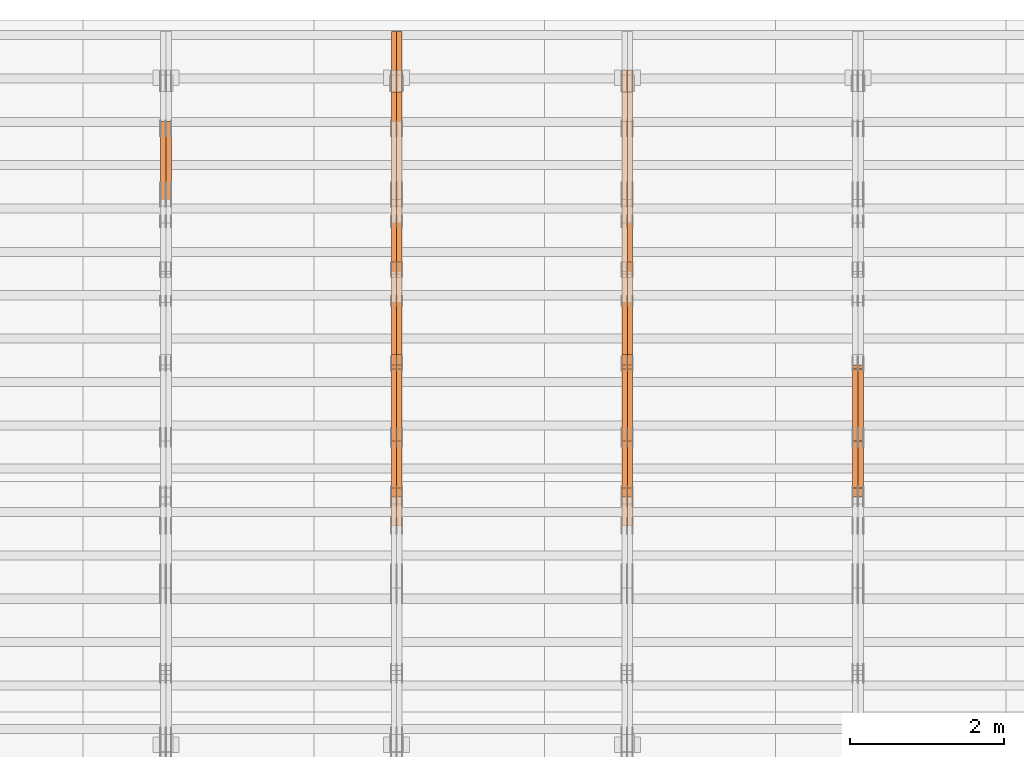
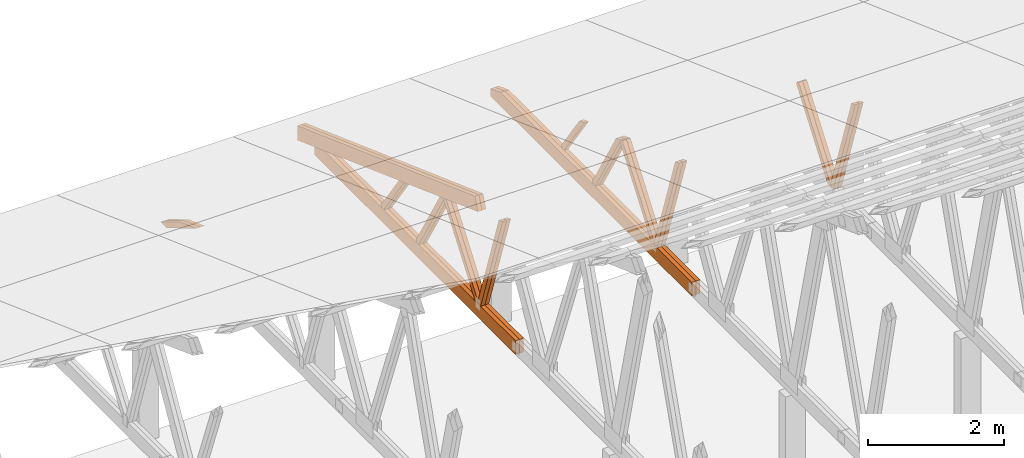
# One storey, part 44 of 189: 27 proxies.
"""IFC2X3 building model written with IfcOpenShell, lengths in millimetres."""

from ifc_helpers import new_model, entity, si_unit, converted_unit, derived_unit, direction, frame, origin, place, context, subcontext, project, spatial, polyline, outline, extrude, source, transform, mapped, material, type_object, type_shapes, element, save


model = new_model("IFC2X3")

# Units and contexts
model_context = context("Model", 3, precision=0.01, world=origin(), true_north=direction((6.12303176911189e-17, 1.0)))
body_context = subcontext(model_context, "Body", "Model", "MODEL_VIEW")
ifc_project = project(units=[si_unit("LENGTHUNIT", "METRE", prefix="MILLI"), si_unit("AREAUNIT", "SQUARE_METRE"), si_unit("VOLUMEUNIT", "CUBIC_METRE"), converted_unit("PLANEANGLEUNIT", "DEGREE", entity("IfcRatioMeasure", 0.0174532925199433), si_unit("PLANEANGLEUNIT", "RADIAN"), dimensions=[0, 0, 0, 0, 0, 0, 0]), si_unit("MASSUNIT", "GRAM", prefix="KILO"), derived_unit("MASSDENSITYUNIT", [(si_unit("MASSUNIT", "GRAM", prefix="KILO"), 1), (si_unit("LENGTHUNIT", "METRE"), -3)]), si_unit("TIMEUNIT", "SECOND"), si_unit("FREQUENCYUNIT", "HERTZ"), si_unit("THERMODYNAMICTEMPERATUREUNIT", "DEGREE_CELSIUS"), derived_unit("THERMALTRANSMITTANCEUNIT", [(si_unit("MASSUNIT", "GRAM", prefix="KILO"), 1), (si_unit("THERMODYNAMICTEMPERATUREUNIT", "KELVIN"), -1), (si_unit("TIMEUNIT", "SECOND"), -3)]), derived_unit("VOLUMETRICFLOWRATEUNIT", [(si_unit("LENGTHUNIT", "METRE"), 3), (si_unit("TIMEUNIT", "SECOND"), -1)]), si_unit("ELECTRICCURRENTUNIT", "AMPERE"), si_unit("ELECTRICVOLTAGEUNIT", "VOLT"), si_unit("POWERUNIT", "WATT"), si_unit("FORCEUNIT", "NEWTON"), si_unit("ILLUMINANCEUNIT", "LUX"), si_unit("LUMINOUSFLUXUNIT", "LUMEN"), si_unit("LUMINOUSINTENSITYUNIT", "CANDELA"), derived_unit("USERDEFINED", [(si_unit("MASSUNIT", "GRAM", prefix="KILO"), -1), (si_unit("LENGTHUNIT", "METRE"), -2), (si_unit("TIMEUNIT", "SECOND"), 3), (si_unit("LUMINOUSFLUXUNIT", "LUMEN"), 1)]), derived_unit("LINEARVELOCITYUNIT", [(si_unit("LENGTHUNIT", "METRE"), 1), (si_unit("TIMEUNIT", "SECOND"), -1)]), si_unit("PRESSUREUNIT", "PASCAL"), derived_unit("USERDEFINED", [(si_unit("LENGTHUNIT", "METRE"), -2), (si_unit("MASSUNIT", "GRAM", prefix="KILO"), 1), (si_unit("TIMEUNIT", "SECOND"), -2)])], contexts=[model_context])

# Site, building, storey
site_placement = place(None, origin())
site = spatial("IfcSite", under=ifc_project, at=site_placement, CompositionType="ELEMENT")
building_placement = place(site_placement, origin())
building = spatial("IfcBuilding", under=site, at=building_placement, CompositionType="ELEMENT")
storey_placement = place(building_placement, origin())
storey = spatial("IfcBuildingStorey", under=building, at=storey_placement, Name="Default", CompositionType="ELEMENT", Elevation=0.0)

# Proxies
ifc_material_1 = material(Name="IfcSurfaceStyle #161130")
building_element_proxy_type_1 = type_object("IfcBuildingElementProxyType", Name="T1-W9 161128", PredefinedType="NOTDEFINED", material=ifc_material_1)
shared_shape_1 = source(origin(), body_context, "Body", "SweptSolid", [
    extrude(outline(polyline([(-1151.44310138162, -47.5000079487596), (776.329826327547, -47.5000079487596), (809.267611644053, -8.1966354137375e-07), (793.242530238244, 47.5000083585914), (-1227.39686682822, 47.5000083585914), (-1151.44310138162, -47.5000079487596)])), frame((809.267685789073, 47.5000083585914, 0.0), z_axis=(0.0, 0.0, 1.0), x_axis=(-1.0, 0.0, 0.0)), (0.0, 0.0, 1.0), 69.9999999999999),
])
type_shapes(building_element_proxy_type_1, [shared_shape_1])
proxy_1_placement = place(building_placement, frame((30300.0, 24600.2198992919, 229.815691184017), z_axis=(-1.0, 0.0, 0.0), x_axis=(0.0, -0.31966811847134, 0.947529574226047)))
element("IfcBuildingElementProxy", 1, at=proxy_1_placement, inside=storey, type_object=building_element_proxy_type_1, material=ifc_material_1, Name="T1-W9", context=body_context, shape_type="MappedRepresentation", body=[
    mapped(shared_shape_1, transform((0.0, 0.0, 0.0), scale=1.0)),
])
ifc_material_2 = material(Name="IfcSurfaceStyle #161064")
building_element_proxy_type_2 = type_object("IfcBuildingElementProxyType", Name="T1-W9 161062", PredefinedType="NOTDEFINED", material=ifc_material_2)
shared_shape_2 = source(origin(), body_context, "Body", "SweptSolid", [
    extrude(outline(polyline([(-1151.44310138162, -47.5000079487596), (776.329826327547, -47.5000079487596), (809.267611644053, -8.1966354137375e-07), (793.242530238244, 47.5000083585914), (-1227.39686682822, 47.5000083585914), (-1151.44310138162, -47.5000079487596)])), frame((809.267685789073, 47.5000083585914, 0.0), z_axis=(0.0, 0.0, 1.0), x_axis=(-1.0, 0.0, 0.0)), (0.0, 0.0, 1.0), 69.9999999999999),
])
type_shapes(building_element_proxy_type_2, [shared_shape_2])
proxy_2_placement = place(building_placement, frame((30230.0, 24600.2198992919, 229.815691184017), z_axis=(-1.0, 0.0, 0.0), x_axis=(0.0, -0.31966811847134, 0.947529574226047)))
element("IfcBuildingElementProxy", 2, at=proxy_2_placement, inside=storey, type_object=building_element_proxy_type_2, material=ifc_material_2, Name="T1-W9", context=body_context, shape_type="MappedRepresentation", body=[
    mapped(shared_shape_2, transform((0.0, 0.0, 0.0), scale=1.0)),
])
ifc_material_3 = material(Name="IfcSurfaceStyle #160866")
building_element_proxy_type_3 = type_object("IfcBuildingElementProxyType", Name="T1-W10 160864", PredefinedType="NOTDEFINED", material=ifc_material_3)
shared_shape_3 = source(origin(), body_context, "Body", "SweptSolid", [
    extrude(outline(polyline([(-993.240970354386, -47.5000757607337), (635.890952815036, -47.5000757607337), (650.068145237537, -1.47580554758164e-05), (629.921374092803, 47.5000831397614), (-922.639501790989, 47.5000831397614), (-993.240970354386, -47.5000757607337)])), frame((650.068173419645, 47.5002811208496, 0.0), z_axis=(0.0, 0.0, 1.0), x_axis=(-1.0, 0.0, 0.0)), (0.0, 0.0, 1.0), 69.9999999999999),
])
type_shapes(building_element_proxy_type_3, [shared_shape_3])
proxy_3_placement = place(building_placement, frame((30300.0, 25701.688098798, 1507.2920009025), z_axis=(-1.0, 0.0, 0.0), x_axis=(0.0, -0.596486092002004, -0.802623412347395)))
element("IfcBuildingElementProxy", 3, at=proxy_3_placement, inside=storey, type_object=building_element_proxy_type_3, material=ifc_material_3, Name="T1-W10", context=body_context, shape_type="MappedRepresentation", body=[
    mapped(shared_shape_3, transform((0.0, 0.0, 0.0), scale=1.0)),
])
ifc_material_4 = material(Name="IfcSurfaceStyle #160800")
building_element_proxy_type_4 = type_object("IfcBuildingElementProxyType", Name="T1-W10 160798", PredefinedType="NOTDEFINED", material=ifc_material_4)
shared_shape_4 = source(origin(), body_context, "Body", "SweptSolid", [
    extrude(outline(polyline([(-993.240970354386, -47.5000757607337), (635.890952815036, -47.5000757607337), (650.068145237537, -1.47580554758164e-05), (629.921374092803, 47.5000831397614), (-922.639501790989, 47.5000831397614), (-993.240970354386, -47.5000757607337)])), frame((650.068173419645, 47.5002811208496, 0.0), z_axis=(0.0, 0.0, 1.0), x_axis=(-1.0, 0.0, 0.0)), (0.0, 0.0, 1.0), 69.9999999999999),
])
type_shapes(building_element_proxy_type_4, [shared_shape_4])
proxy_4_placement = place(building_placement, frame((30230.0, 25701.688098798, 1507.2920009025), z_axis=(-1.0, 0.0, 0.0), x_axis=(0.0, -0.596486092002004, -0.802623412347395)))
element("IfcBuildingElementProxy", 4, at=proxy_4_placement, inside=storey, type_object=building_element_proxy_type_4, material=ifc_material_4, Name="T1-W10", context=body_context, shape_type="MappedRepresentation", body=[
    mapped(shared_shape_4, transform((0.0, 0.0, 0.0), scale=1.0)),
])
ifc_material_5 = material(Name="IfcSurfaceStyle #145340")
building_element_proxy_type_5 = type_object("IfcBuildingElementProxyType", Name="T1-W9 145338", PredefinedType="NOTDEFINED", material=ifc_material_5)
shared_shape_5 = source(origin(), body_context, "Body", "SweptSolid", [
    extrude(outline(polyline([(-1151.44310138162, -47.5000079487596), (776.329826327547, -47.5000079487596), (809.267611644053, -8.1966354137375e-07), (793.242530238244, 47.5000083585914), (-1227.39686682822, 47.5000083585914), (-1151.44310138162, -47.5000079487596)])), frame((809.267685789073, 47.5000083585914, 0.0), z_axis=(0.0, 0.0, 1.0), x_axis=(-1.0, 0.0, 0.0)), (0.0, 0.0, 1.0), 69.9999999999999),
])
type_shapes(building_element_proxy_type_5, [shared_shape_5])
proxy_5_placement = place(building_placement, frame((27300.0, 24600.2198992919, 229.815691184017), z_axis=(-1.0, 0.0, 0.0), x_axis=(0.0, -0.31966811847134, 0.947529574226047)))
element("IfcBuildingElementProxy", 5, at=proxy_5_placement, inside=storey, type_object=building_element_proxy_type_5, material=ifc_material_5, Name="T1-W9", context=body_context, shape_type="MappedRepresentation", body=[
    mapped(shared_shape_5, transform((0.0, 0.0, 0.0), scale=1.0)),
])
ifc_material_6 = material(Name="IfcSurfaceStyle #145274")
building_element_proxy_type_6 = type_object("IfcBuildingElementProxyType", Name="T1-W9 145272", PredefinedType="NOTDEFINED", material=ifc_material_6)
shared_shape_6 = source(origin(), body_context, "Body", "SweptSolid", [
    extrude(outline(polyline([(-1151.44310138162, -47.5000079487596), (776.329826327547, -47.5000079487596), (809.267611644053, -8.1966354137375e-07), (793.242530238244, 47.5000083585914), (-1227.39686682822, 47.5000083585914), (-1151.44310138162, -47.5000079487596)])), frame((809.267685789073, 47.5000083585914, 0.0), z_axis=(0.0, 0.0, 1.0), x_axis=(-1.0, 0.0, 0.0)), (0.0, 0.0, 1.0), 69.9999999999999),
])
type_shapes(building_element_proxy_type_6, [shared_shape_6])
proxy_6_placement = place(building_placement, frame((27230.0, 24600.2198992919, 229.815691184017), z_axis=(-1.0, 0.0, 0.0), x_axis=(0.0, -0.31966811847134, 0.947529574226047)))
element("IfcBuildingElementProxy", 6, at=proxy_6_placement, inside=storey, type_object=building_element_proxy_type_6, material=ifc_material_6, Name="T1-W9", context=body_context, shape_type="MappedRepresentation", body=[
    mapped(shared_shape_6, transform((0.0, 0.0, 0.0), scale=1.0)),
])
ifc_material_7 = material(Name="IfcSurfaceStyle #145076")
building_element_proxy_type_7 = type_object("IfcBuildingElementProxyType", Name="T1-W10 145074", PredefinedType="NOTDEFINED", material=ifc_material_7)
shared_shape_7 = source(origin(), body_context, "Body", "SweptSolid", [
    extrude(outline(polyline([(-993.240970354386, -47.5000757607337), (635.890952815036, -47.5000757607337), (650.068145237537, -1.47580554758164e-05), (629.921374092803, 47.5000831397614), (-922.639501790989, 47.5000831397614), (-993.240970354386, -47.5000757607337)])), frame((650.068173419645, 47.5002811208496, 0.0), z_axis=(0.0, 0.0, 1.0), x_axis=(-1.0, 0.0, 0.0)), (0.0, 0.0, 1.0), 69.9999999999999),
])
type_shapes(building_element_proxy_type_7, [shared_shape_7])
proxy_7_placement = place(building_placement, frame((27300.0, 25701.688098798, 1507.2920009025), z_axis=(-1.0, 0.0, 0.0), x_axis=(0.0, -0.596486092002004, -0.802623412347395)))
element("IfcBuildingElementProxy", 7, at=proxy_7_placement, inside=storey, type_object=building_element_proxy_type_7, material=ifc_material_7, Name="T1-W10", context=body_context, shape_type="MappedRepresentation", body=[
    mapped(shared_shape_7, transform((0.0, 0.0, 0.0), scale=1.0)),
])
ifc_material_8 = material(Name="IfcSurfaceStyle #145010")
building_element_proxy_type_8 = type_object("IfcBuildingElementProxyType", Name="T1-W10 145008", PredefinedType="NOTDEFINED", material=ifc_material_8)
shared_shape_8 = source(origin(), body_context, "Body", "SweptSolid", [
    extrude(outline(polyline([(-993.240970354386, -47.5000757607337), (635.890952815036, -47.5000757607337), (650.068145237537, -1.47580554758164e-05), (629.921374092803, 47.5000831397614), (-922.639501790989, 47.5000831397614), (-993.240970354386, -47.5000757607337)])), frame((650.068173419645, 47.5002811208496, 0.0), z_axis=(0.0, 0.0, 1.0), x_axis=(-1.0, 0.0, 0.0)), (0.0, 0.0, 1.0), 69.9999999999999),
])
type_shapes(building_element_proxy_type_8, [shared_shape_8])
proxy_8_placement = place(building_placement, frame((27230.0, 25701.688098798, 1507.2920009025), z_axis=(-1.0, 0.0, 0.0), x_axis=(0.0, -0.596486092002004, -0.802623412347395)))
element("IfcBuildingElementProxy", 8, at=proxy_8_placement, inside=storey, type_object=building_element_proxy_type_8, material=ifc_material_8, Name="T1-W10", context=body_context, shape_type="MappedRepresentation", body=[
    mapped(shared_shape_8, transform((0.0, 0.0, 0.0), scale=1.0)),
])
ifc_material_9 = material(Name="IfcSurfaceStyle #144812")
building_element_proxy_type_9 = type_object("IfcBuildingElementProxyType", Name="T1-W11 144810", PredefinedType="NOTDEFINED", material=ifc_material_9)
shared_shape_9 = source(origin(), body_context, "Body", "SweptSolid", [
    extrude(outline(polyline([(-809.410890003667, -47.5000077306544), (561.624013869753, -47.5000077306544), (599.944137054867, -7.52294285037536e-05), (572.078784657538, 47.5000453453687), (-924.236045578491, 47.5000453453687), (-809.410890003667, -47.5000077306544)])), frame((599.944137054867, 47.5000453453687, 0.0), z_axis=(0.0, 0.0, 1.0), x_axis=(-1.0, 0.0, 0.0)), (0.0, 0.0, 1.0), 69.9999999999999),
])
type_shapes(building_element_proxy_type_9, [shared_shape_9])
proxy_9_placement = place(building_placement, frame((27300.0, 26434.7921369083, 220.965133687368), z_axis=(-1.0, 0.0, 0.0), x_axis=(0.0, -0.505995901100603, 0.862535882192381)))
element("IfcBuildingElementProxy", 9, at=proxy_9_placement, inside=storey, type_object=building_element_proxy_type_9, material=ifc_material_9, Name="T1-W11", context=body_context, shape_type="MappedRepresentation", body=[
    mapped(shared_shape_9, transform((0.0, 0.0, 0.0), scale=1.0)),
])
ifc_material_10 = material(Name="IfcSurfaceStyle #144746")
building_element_proxy_type_10 = type_object("IfcBuildingElementProxyType", Name="T1-W11 144744", PredefinedType="NOTDEFINED", material=ifc_material_10)
shared_shape_10 = source(origin(), body_context, "Body", "SweptSolid", [
    extrude(outline(polyline([(-809.410890003667, -47.5000077306544), (561.624013869753, -47.5000077306544), (599.944137054867, -7.52294285037536e-05), (572.078784657538, 47.5000453453687), (-924.236045578491, 47.5000453453687), (-809.410890003667, -47.5000077306544)])), frame((599.944137054867, 47.5000453453687, 0.0), z_axis=(0.0, 0.0, 1.0), x_axis=(-1.0, 0.0, 0.0)), (0.0, 0.0, 1.0), 69.9999999999999),
])
type_shapes(building_element_proxy_type_10, [shared_shape_10])
proxy_10_placement = place(building_placement, frame((27230.0, 26434.7921369083, 220.965133687368), z_axis=(-1.0, 0.0, 0.0), x_axis=(0.0, -0.505995901100603, 0.862535882192381)))
element("IfcBuildingElementProxy", 10, at=proxy_10_placement, inside=storey, type_object=building_element_proxy_type_10, material=ifc_material_10, Name="T1-W11", context=body_context, shape_type="MappedRepresentation", body=[
    mapped(shared_shape_10, transform((0.0, 0.0, 0.0), scale=1.0)),
])
ifc_material_11 = material(Name="IfcSurfaceStyle #144284")
building_element_proxy_type_11 = type_object("IfcBuildingElementProxyType", Name="T1-W13 144282", PredefinedType="NOTDEFINED", material=ifc_material_11)
shared_shape_11 = source(origin(), body_context, "Body", "SweptSolid", [
    extrude(outline(polyline([(-527.416466728212, -47.5000272833949), (387.658053197984, -47.5000272833949), (418.029495084182, -7.96824534414764e-06), (384.779443025059, 47.5000312675175), (-663.050524579013, 47.5000312675176), (-527.416466728212, -47.5000272833949)])), frame((418.029495084182, 47.5000671658844, 0.0), z_axis=(0.0, 0.0, 1.0), x_axis=(-1.0, 0.0, 0.0)), (0.0, 0.0, 1.0), 69.9999999999999),
])
type_shapes(building_element_proxy_type_11, [shared_shape_11])
proxy_11_placement = place(building_placement, frame((27300.0, 27471.0085508293, 217.760482033818), z_axis=(-1.0, 0.0, 0.0), x_axis=(0.0, -0.573462629043498, 0.819231721242848)))
element("IfcBuildingElementProxy", 11, at=proxy_11_placement, inside=storey, type_object=building_element_proxy_type_11, material=ifc_material_11, Name="T1-W13", context=body_context, shape_type="MappedRepresentation", body=[
    mapped(shared_shape_11, transform((0.0, 0.0, 0.0), scale=1.0)),
])
ifc_material_12 = material(Name="IfcSurfaceStyle #143660")
building_element_proxy_type_12 = type_object("IfcBuildingElementProxyType", Name="T1-B1 143658", PredefinedType="NOTDEFINED", material=ifc_material_12)
shared_shape_12 = source(origin(), body_context, "Body", "SweptSolid", [
    extrude(outline(polyline([(-2430.09461669922, -125.855288696288), (3499.90538330078, -125.855288696288), (3499.90538330078, 119.144711303711), (-2139.62153320312, 119.144711303711), (-2430.09461669922, 13.4211547851552), (-2430.09461669922, -125.855288696288)])), frame((3499.90538330078, 119.144711303711, 0.0), z_axis=(0.0, 0.0, 1.0), x_axis=(-1.0, 0.0, 0.0)), (0.0, 0.0, 1.0), 69.9999999999996),
])
type_shapes(building_element_proxy_type_12, [shared_shape_12])
proxy_12_placement = place(building_placement, frame((27300.0, 23570.0, 245.0), z_axis=(-1.0, 0.0, 0.0), x_axis=(0.0, 1.0, 0.0)))
element("IfcBuildingElementProxy", 12, at=proxy_12_placement, inside=storey, type_object=building_element_proxy_type_12, material=ifc_material_12, Name="T1-B1", context=body_context, shape_type="MappedRepresentation", body=[
    mapped(shared_shape_12, transform((0.0, 0.0, 0.0), scale=1.0)),
])
ifc_material_13 = material(Name="IfcSurfaceStyle #143594")
building_element_proxy_type_13 = type_object("IfcBuildingElementProxyType", Name="T1-B1 143592", PredefinedType="NOTDEFINED", material=ifc_material_13)
shared_shape_13 = source(origin(), body_context, "Body", "SweptSolid", [
    extrude(outline(polyline([(-2430.09461669922, -125.855288696288), (3499.90538330078, -125.855288696288), (3499.90538330078, 119.144711303711), (-2139.62153320312, 119.144711303711), (-2430.09461669922, 13.4211547851552), (-2430.09461669922, -125.855288696288)])), frame((3499.90538330078, 119.144711303711, 0.0), z_axis=(0.0, 0.0, 1.0), x_axis=(-1.0, 0.0, 0.0)), (0.0, 0.0, 1.0), 69.9999999999996),
])
type_shapes(building_element_proxy_type_13, [shared_shape_13])
proxy_13_placement = place(building_placement, frame((27230.0, 23570.0, 245.0), z_axis=(-1.0, 0.0, 0.0), x_axis=(0.0, 1.0, 0.0)))
element("IfcBuildingElementProxy", 13, at=proxy_13_placement, inside=storey, type_object=building_element_proxy_type_13, material=ifc_material_13, Name="T1-B1", context=body_context, shape_type="MappedRepresentation", body=[
    mapped(shared_shape_13, transform((0.0, 0.0, 0.0), scale=1.0)),
])
ifc_material_14 = material(Name="IfcSurfaceStyle #129550")
building_element_proxy_type_14 = type_object("IfcBuildingElementProxyType", Name="T1-W9 129548", PredefinedType="NOTDEFINED", material=ifc_material_14)
shared_shape_14 = source(origin(), body_context, "Body", "SweptSolid", [
    extrude(outline(polyline([(-1151.44310138162, -47.5000079487596), (776.329826327547, -47.5000079487596), (809.267611644053, -8.1966354137375e-07), (793.242530238244, 47.5000083585914), (-1227.39686682822, 47.5000083585914), (-1151.44310138162, -47.5000079487596)])), frame((809.267685789073, 47.5000083585914, 0.0), z_axis=(0.0, 0.0, 1.0), x_axis=(-1.0, 0.0, 0.0)), (0.0, 0.0, 1.0), 69.9999999999999),
])
type_shapes(building_element_proxy_type_14, [shared_shape_14])
proxy_14_placement = place(building_placement, frame((24300.0, 24600.2198992919, 229.815691184017), z_axis=(-1.0, 0.0, 0.0), x_axis=(0.0, -0.31966811847134, 0.947529574226047)))
element("IfcBuildingElementProxy", 14, at=proxy_14_placement, inside=storey, type_object=building_element_proxy_type_14, material=ifc_material_14, Name="T1-W9", context=body_context, shape_type="MappedRepresentation", body=[
    mapped(shared_shape_14, transform((0.0, 0.0, 0.0), scale=1.0)),
])
ifc_material_15 = material(Name="IfcSurfaceStyle #129484")
building_element_proxy_type_15 = type_object("IfcBuildingElementProxyType", Name="T1-W9 129482", PredefinedType="NOTDEFINED", material=ifc_material_15)
shared_shape_15 = source(origin(), body_context, "Body", "SweptSolid", [
    extrude(outline(polyline([(-1151.44310138162, -47.5000079487596), (776.329826327547, -47.5000079487596), (809.267611644053, -8.1966354137375e-07), (793.242530238244, 47.5000083585914), (-1227.39686682822, 47.5000083585914), (-1151.44310138162, -47.5000079487596)])), frame((809.267685789073, 47.5000083585914, 0.0), z_axis=(0.0, 0.0, 1.0), x_axis=(-1.0, 0.0, 0.0)), (0.0, 0.0, 1.0), 69.9999999999999),
])
type_shapes(building_element_proxy_type_15, [shared_shape_15])
proxy_15_placement = place(building_placement, frame((24230.0, 24600.2198992919, 229.815691184017), z_axis=(-1.0, 0.0, 0.0), x_axis=(0.0, -0.31966811847134, 0.947529574226047)))
element("IfcBuildingElementProxy", 15, at=proxy_15_placement, inside=storey, type_object=building_element_proxy_type_15, material=ifc_material_15, Name="T1-W9", context=body_context, shape_type="MappedRepresentation", body=[
    mapped(shared_shape_15, transform((0.0, 0.0, 0.0), scale=1.0)),
])
ifc_material_16 = material(Name="IfcSurfaceStyle #129286")
building_element_proxy_type_16 = type_object("IfcBuildingElementProxyType", Name="T1-W10 129284", PredefinedType="NOTDEFINED", material=ifc_material_16)
shared_shape_16 = source(origin(), body_context, "Body", "SweptSolid", [
    extrude(outline(polyline([(-993.240970354386, -47.5000757607337), (635.890952815036, -47.5000757607337), (650.068145237537, -1.47580554758164e-05), (629.921374092803, 47.5000831397614), (-922.639501790989, 47.5000831397614), (-993.240970354386, -47.5000757607337)])), frame((650.068173419645, 47.5002811208496, 0.0), z_axis=(0.0, 0.0, 1.0), x_axis=(-1.0, 0.0, 0.0)), (0.0, 0.0, 1.0), 69.9999999999999),
])
type_shapes(building_element_proxy_type_16, [shared_shape_16])
proxy_16_placement = place(building_placement, frame((24300.0, 25701.688098798, 1507.2920009025), z_axis=(-1.0, 0.0, 0.0), x_axis=(0.0, -0.596486092002004, -0.802623412347395)))
element("IfcBuildingElementProxy", 16, at=proxy_16_placement, inside=storey, type_object=building_element_proxy_type_16, material=ifc_material_16, Name="T1-W10", context=body_context, shape_type="MappedRepresentation", body=[
    mapped(shared_shape_16, transform((0.0, 0.0, 0.0), scale=1.0)),
])
ifc_material_17 = material(Name="IfcSurfaceStyle #129220")
building_element_proxy_type_17 = type_object("IfcBuildingElementProxyType", Name="T1-W10 129218", PredefinedType="NOTDEFINED", material=ifc_material_17)
shared_shape_17 = source(origin(), body_context, "Body", "SweptSolid", [
    extrude(outline(polyline([(-993.240970354386, -47.5000757607337), (635.890952815036, -47.5000757607337), (650.068145237537, -1.47580554758164e-05), (629.921374092803, 47.5000831397614), (-922.639501790989, 47.5000831397614), (-993.240970354386, -47.5000757607337)])), frame((650.068173419645, 47.5002811208496, 0.0), z_axis=(0.0, 0.0, 1.0), x_axis=(-1.0, 0.0, 0.0)), (0.0, 0.0, 1.0), 69.9999999999999),
])
type_shapes(building_element_proxy_type_17, [shared_shape_17])
proxy_17_placement = place(building_placement, frame((24230.0, 25701.688098798, 1507.2920009025), z_axis=(-1.0, 0.0, 0.0), x_axis=(0.0, -0.596486092002004, -0.802623412347395)))
element("IfcBuildingElementProxy", 17, at=proxy_17_placement, inside=storey, type_object=building_element_proxy_type_17, material=ifc_material_17, Name="T1-W10", context=body_context, shape_type="MappedRepresentation", body=[
    mapped(shared_shape_17, transform((0.0, 0.0, 0.0), scale=1.0)),
])
ifc_material_18 = material(Name="IfcSurfaceStyle #129022")
building_element_proxy_type_18 = type_object("IfcBuildingElementProxyType", Name="T1-W11 129020", PredefinedType="NOTDEFINED", material=ifc_material_18)
shared_shape_18 = source(origin(), body_context, "Body", "SweptSolid", [
    extrude(outline(polyline([(-809.410890003667, -47.5000077306544), (561.624013869753, -47.5000077306544), (599.944137054867, -7.52294285037536e-05), (572.078784657538, 47.5000453453687), (-924.236045578491, 47.5000453453687), (-809.410890003667, -47.5000077306544)])), frame((599.944137054867, 47.5000453453687, 0.0), z_axis=(0.0, 0.0, 1.0), x_axis=(-1.0, 0.0, 0.0)), (0.0, 0.0, 1.0), 69.9999999999999),
])
type_shapes(building_element_proxy_type_18, [shared_shape_18])
proxy_18_placement = place(building_placement, frame((24300.0, 26434.7921369083, 220.965133687368), z_axis=(-1.0, 0.0, 0.0), x_axis=(0.0, -0.505995901100603, 0.862535882192381)))
element("IfcBuildingElementProxy", 18, at=proxy_18_placement, inside=storey, type_object=building_element_proxy_type_18, material=ifc_material_18, Name="T1-W11", context=body_context, shape_type="MappedRepresentation", body=[
    mapped(shared_shape_18, transform((0.0, 0.0, 0.0), scale=1.0)),
])
ifc_material_19 = material(Name="IfcSurfaceStyle #128956")
building_element_proxy_type_19 = type_object("IfcBuildingElementProxyType", Name="T1-W11 128954", PredefinedType="NOTDEFINED", material=ifc_material_19)
shared_shape_19 = source(origin(), body_context, "Body", "SweptSolid", [
    extrude(outline(polyline([(-809.410890003667, -47.5000077306544), (561.624013869753, -47.5000077306544), (599.944137054867, -7.52294285037536e-05), (572.078784657538, 47.5000453453687), (-924.236045578491, 47.5000453453687), (-809.410890003667, -47.5000077306544)])), frame((599.944137054867, 47.5000453453687, 0.0), z_axis=(0.0, 0.0, 1.0), x_axis=(-1.0, 0.0, 0.0)), (0.0, 0.0, 1.0), 69.9999999999999),
])
type_shapes(building_element_proxy_type_19, [shared_shape_19])
proxy_19_placement = place(building_placement, frame((24230.0, 26434.7921369083, 220.965133687368), z_axis=(-1.0, 0.0, 0.0), x_axis=(0.0, -0.505995901100603, 0.862535882192381)))
element("IfcBuildingElementProxy", 19, at=proxy_19_placement, inside=storey, type_object=building_element_proxy_type_19, material=ifc_material_19, Name="T1-W11", context=body_context, shape_type="MappedRepresentation", body=[
    mapped(shared_shape_19, transform((0.0, 0.0, 0.0), scale=1.0)),
])
ifc_material_20 = material(Name="IfcSurfaceStyle #128494")
building_element_proxy_type_20 = type_object("IfcBuildingElementProxyType", Name="T1-W13 128492", PredefinedType="NOTDEFINED", material=ifc_material_20)
shared_shape_20 = source(origin(), body_context, "Body", "SweptSolid", [
    extrude(outline(polyline([(-527.416466728212, -47.5000272833949), (387.658053197984, -47.5000272833949), (418.029495084182, -7.96824534414764e-06), (384.779443025059, 47.5000312675175), (-663.050524579013, 47.5000312675176), (-527.416466728212, -47.5000272833949)])), frame((418.029495084182, 47.5000671658844, 0.0), z_axis=(0.0, 0.0, 1.0), x_axis=(-1.0, 0.0, 0.0)), (0.0, 0.0, 1.0), 69.9999999999999),
])
type_shapes(building_element_proxy_type_20, [shared_shape_20])
proxy_20_placement = place(building_placement, frame((24300.0, 27471.0085508293, 217.760482033818), z_axis=(-1.0, 0.0, 0.0), x_axis=(0.0, -0.573462629043498, 0.819231721242848)))
element("IfcBuildingElementProxy", 20, at=proxy_20_placement, inside=storey, type_object=building_element_proxy_type_20, material=ifc_material_20, Name="T1-W13", context=body_context, shape_type="MappedRepresentation", body=[
    mapped(shared_shape_20, transform((0.0, 0.0, 0.0), scale=1.0)),
])
ifc_material_21 = material(Name="IfcSurfaceStyle #128428")
building_element_proxy_type_21 = type_object("IfcBuildingElementProxyType", Name="T1-W13 128426", PredefinedType="NOTDEFINED", material=ifc_material_21)
shared_shape_21 = source(origin(), body_context, "Body", "SweptSolid", [
    extrude(outline(polyline([(-527.416466728212, -47.5000272833949), (387.658053197984, -47.5000272833949), (418.029495084182, -7.96824534414764e-06), (384.779443025059, 47.5000312675175), (-663.050524579013, 47.5000312675176), (-527.416466728212, -47.5000272833949)])), frame((418.029495084182, 47.5000671658844, 0.0), z_axis=(0.0, 0.0, 1.0), x_axis=(-1.0, 0.0, 0.0)), (0.0, 0.0, 1.0), 69.9999999999999),
])
type_shapes(building_element_proxy_type_21, [shared_shape_21])
proxy_21_placement = place(building_placement, frame((24230.0, 27471.0085508293, 217.760482033818), z_axis=(-1.0, 0.0, 0.0), x_axis=(0.0, -0.573462629043498, 0.819231721242848)))
element("IfcBuildingElementProxy", 21, at=proxy_21_placement, inside=storey, type_object=building_element_proxy_type_21, material=ifc_material_21, Name="T1-W13", context=body_context, shape_type="MappedRepresentation", body=[
    mapped(shared_shape_21, transform((0.0, 0.0, 0.0), scale=1.0)),
])
ifc_material_22 = material(Name="IfcSurfaceStyle #127870")
building_element_proxy_type_22 = type_object("IfcBuildingElementProxyType", Name="T1-B1 127868", PredefinedType="NOTDEFINED", material=ifc_material_22)
shared_shape_22 = source(origin(), body_context, "Body", "SweptSolid", [
    extrude(outline(polyline([(-2430.09461669922, -125.855288696288), (3499.90538330078, -125.855288696288), (3499.90538330078, 119.144711303711), (-2139.62153320312, 119.144711303711), (-2430.09461669922, 13.4211547851552), (-2430.09461669922, -125.855288696288)])), frame((3499.90538330078, 119.144711303711, 0.0), z_axis=(0.0, 0.0, 1.0), x_axis=(-1.0, 0.0, 0.0)), (0.0, 0.0, 1.0), 69.9999999999996),
])
type_shapes(building_element_proxy_type_22, [shared_shape_22])
proxy_22_placement = place(building_placement, frame((24300.0, 23570.0, 245.0), z_axis=(-1.0, 0.0, 0.0), x_axis=(0.0, 1.0, 0.0)))
element("IfcBuildingElementProxy", 22, at=proxy_22_placement, inside=storey, type_object=building_element_proxy_type_22, material=ifc_material_22, Name="T1-B1", context=body_context, shape_type="MappedRepresentation", body=[
    mapped(shared_shape_22, transform((0.0, 0.0, 0.0), scale=1.0)),
])
ifc_material_23 = material(Name="IfcSurfaceStyle #127804")
building_element_proxy_type_23 = type_object("IfcBuildingElementProxyType", Name="T1-B1 127802", PredefinedType="NOTDEFINED", material=ifc_material_23)
shared_shape_23 = source(origin(), body_context, "Body", "SweptSolid", [
    extrude(outline(polyline([(-2430.09461669922, -125.855288696288), (3499.90538330078, -125.855288696288), (3499.90538330078, 119.144711303711), (-2139.62153320312, 119.144711303711), (-2430.09461669922, 13.4211547851552), (-2430.09461669922, -125.855288696288)])), frame((3499.90538330078, 119.144711303711, 0.0), z_axis=(0.0, 0.0, 1.0), x_axis=(-1.0, 0.0, 0.0)), (0.0, 0.0, 1.0), 69.9999999999996),
])
type_shapes(building_element_proxy_type_23, [shared_shape_23])
proxy_23_placement = place(building_placement, frame((24230.0, 23570.0, 245.0), z_axis=(-1.0, 0.0, 0.0), x_axis=(0.0, 1.0, 0.0)))
element("IfcBuildingElementProxy", 23, at=proxy_23_placement, inside=storey, type_object=building_element_proxy_type_23, material=ifc_material_23, Name="T1-B1", context=body_context, shape_type="MappedRepresentation", body=[
    mapped(shared_shape_23, transform((0.0, 0.0, 0.0), scale=1.0)),
])
ifc_material_24 = material(Name="IfcSurfaceStyle #126580")
building_element_proxy_type_24 = type_object("IfcBuildingElementProxyType", Name="T1-T2 126578", PredefinedType="NOTDEFINED", material=ifc_material_24)
shared_shape_24 = source(origin(), body_context, "Body", "SweptSolid", [
    extrude(outline(polyline([(-2807.70681121203, -122.500041939424), (2763.12044548192, -122.500041939424), (2852.29315104137, 122.500041939424), (-2807.70678531126, 122.500041939424), (-2807.70681121203, -122.500041939424)])), frame((2852.29315104137, 122.500041939424, 0.0), z_axis=(0.0, 0.0, 1.0), x_axis=(-1.0, 0.0, 0.0)), (0.0, 0.0, 1.0), 69.9999999999997),
])
type_shapes(building_element_proxy_type_24, [shared_shape_24])
proxy_24_placement = place(building_placement, frame((24300.0, 30000.0, -42.7086715698242), z_axis=(-1.0, 0.0, 0.0), x_axis=(0.0, -0.939692620785908, 0.342020143325669)))
element("IfcBuildingElementProxy", 24, at=proxy_24_placement, inside=storey, type_object=building_element_proxy_type_24, material=ifc_material_24, Name="T1-T2", context=body_context, shape_type="MappedRepresentation", body=[
    mapped(shared_shape_24, transform((0.0, 0.0, 0.0), scale=1.0)),
])
ifc_material_25 = material(Name="IfcSurfaceStyle #126523")
building_element_proxy_type_25 = type_object("IfcBuildingElementProxyType", Name="T1-T2 126521", PredefinedType="NOTDEFINED", material=ifc_material_25)
shared_shape_25 = source(origin(), body_context, "Body", "SweptSolid", [
    extrude(outline(polyline([(-2807.70681121203, -122.500041939424), (2763.12044548192, -122.500041939424), (2852.29315104137, 122.500041939424), (-2807.70678531126, 122.500041939424), (-2807.70681121203, -122.500041939424)])), frame((2852.29315104137, 122.500041939424, 0.0), z_axis=(0.0, 0.0, 1.0), x_axis=(-1.0, 0.0, 0.0)), (0.0, 0.0, 1.0), 69.9999999999997),
])
type_shapes(building_element_proxy_type_25, [shared_shape_25])
proxy_25_placement = place(building_placement, frame((24230.0, 30000.0, -42.7086715698242), z_axis=(-1.0, 0.0, 0.0), x_axis=(0.0, -0.939692620785908, 0.342020143325669)))
element("IfcBuildingElementProxy", 25, at=proxy_25_placement, inside=storey, type_object=building_element_proxy_type_25, material=ifc_material_25, Name="T1-T2", context=body_context, shape_type="MappedRepresentation", body=[
    mapped(shared_shape_25, transform((0.0, 0.0, 0.0), scale=1.0)),
])
ifc_material_26 = material(Name="IfcSurfaceStyle #112194")
building_element_proxy_type_26 = type_object("IfcBuildingElementProxyType", Name="T1-W12 112192", PredefinedType="NOTDEFINED", material=ifc_material_26)
shared_shape_26 = source(origin(), body_context, "Body", "SweptSolid", [
    extrude(outline(polyline([(-176.861423449428, -47.5000064161489), (503.856777435794, -47.5000064161489), (344.893496040196, 47.5000064161489), (-671.888850026563, 47.5000064161488), (-176.861423449428, -47.5000064161489)])), frame((503.856799890979, 47.5000428456028, 0.0), z_axis=(0.0, 0.0, 1.0), x_axis=(-1.0, 0.0, 0.0)), (0.0, 0.0, 1.0), 69.9999999999999),
])
type_shapes(building_element_proxy_type_26, [shared_shape_26])
proxy_26_placement = place(building_placement, frame((21300.0, 28785.6842742264, 163.452728724015), z_axis=(-1.0, 0.0, 0.0), x_axis=(0.0, -0.858392121304013, 0.51299411895576)))
element("IfcBuildingElementProxy", 26, at=proxy_26_placement, inside=storey, type_object=building_element_proxy_type_26, material=ifc_material_26, Name="T1-W12", context=body_context, shape_type="MappedRepresentation", body=[
    mapped(shared_shape_26, transform((0.0, 0.0, 0.0), scale=1.0)),
])
ifc_material_27 = material(Name="IfcSurfaceStyle #112137")
building_element_proxy_type_27 = type_object("IfcBuildingElementProxyType", Name="T1-W12 112135", PredefinedType="NOTDEFINED", material=ifc_material_27)
shared_shape_27 = source(origin(), body_context, "Body", "SweptSolid", [
    extrude(outline(polyline([(-176.861423449428, -47.5000064161489), (503.856777435794, -47.5000064161489), (344.893496040196, 47.5000064161489), (-671.888850026563, 47.5000064161488), (-176.861423449428, -47.5000064161489)])), frame((503.856799890979, 47.5000428456028, 0.0), z_axis=(0.0, 0.0, 1.0), x_axis=(-1.0, 0.0, 0.0)), (0.0, 0.0, 1.0), 69.9999999999999),
])
type_shapes(building_element_proxy_type_27, [shared_shape_27])
proxy_27_placement = place(building_placement, frame((21230.0, 28785.6842742264, 163.452728724015), z_axis=(-1.0, 0.0, 0.0), x_axis=(0.0, -0.858392121304013, 0.51299411895576)))
element("IfcBuildingElementProxy", 27, at=proxy_27_placement, inside=storey, type_object=building_element_proxy_type_27, material=ifc_material_27, Name="T1-W12", context=body_context, shape_type="MappedRepresentation", body=[
    mapped(shared_shape_27, transform((0.0, 0.0, 0.0), scale=1.0)),
])

save(model, "model.ifc")
